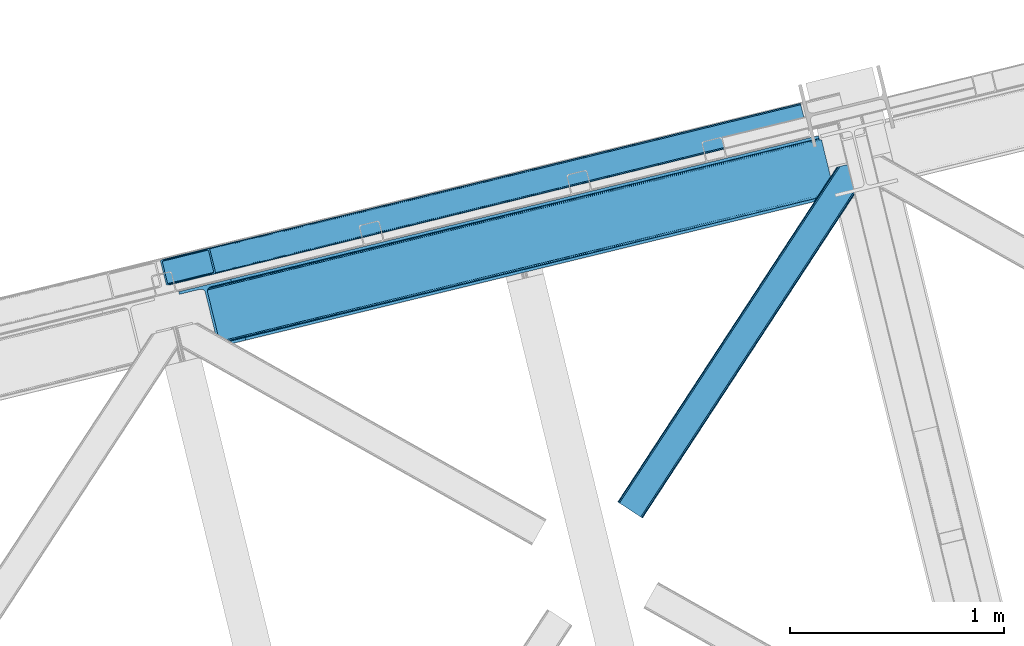
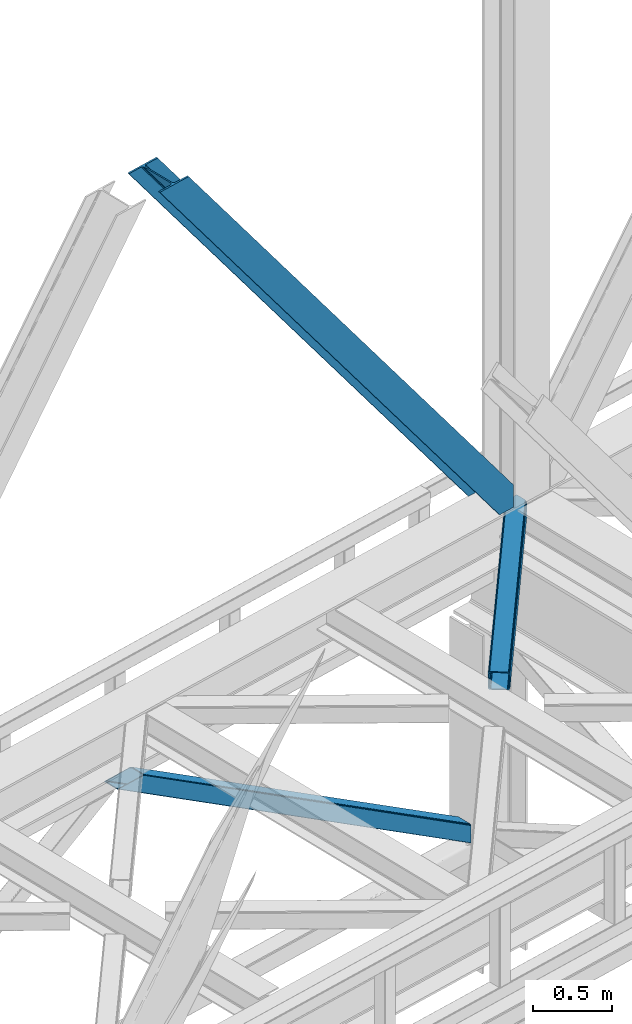
# One storey, part 49 of 93: 3 members.
"""IFC4 building model written with IfcOpenShell, lengths in millimetres."""

from ifc_helpers import new_model, entity, si_unit, converted_unit, derived_unit, direction, frame, origin, place, context, subcontext, project, spatial, triangles, type_object, element, save


model = new_model("IFC4")

# Units and contexts
model_context = context("Model", 3, precision=0.01, world=origin(), true_north=direction((6.12303176911189e-17, 1.0)))
plan_context = context("Plan", 3, precision=0.01, world=origin(), true_north=direction((6.12303176911189e-17, 1.0)))
body_context = subcontext(model_context, "Body", "Model", "MODEL_VIEW")
ifc_project = project(units=[si_unit("LENGTHUNIT", "METRE", prefix="MILLI"), si_unit("AREAUNIT", "SQUARE_METRE"), si_unit("VOLUMEUNIT", "CUBIC_METRE"), converted_unit("PLANEANGLEUNIT", "DEGREE", entity("IfcRatioMeasure", 0.0174532925199433), si_unit("PLANEANGLEUNIT", "RADIAN"), dimensions=[0, 0, 0, 0, 0, 0, 0]), si_unit("MASSUNIT", "GRAM", prefix="KILO"), derived_unit("MASSDENSITYUNIT", [(si_unit("MASSUNIT", "GRAM", prefix="KILO"), 1), (si_unit("LENGTHUNIT", "METRE"), -3)]), derived_unit("MOMENTOFINERTIAUNIT", [(si_unit("LENGTHUNIT", "METRE"), 4)]), si_unit("TIMEUNIT", "SECOND"), si_unit("FREQUENCYUNIT", "HERTZ"), si_unit("THERMODYNAMICTEMPERATUREUNIT", "DEGREE_CELSIUS"), derived_unit("THERMALTRANSMITTANCEUNIT", [(si_unit("MASSUNIT", "GRAM", prefix="KILO"), 1), (si_unit("THERMODYNAMICTEMPERATUREUNIT", "KELVIN"), -1), (si_unit("TIMEUNIT", "SECOND"), -3)]), derived_unit("VOLUMETRICFLOWRATEUNIT", [(si_unit("LENGTHUNIT", "METRE"), 3), (si_unit("TIMEUNIT", "SECOND"), -1)]), derived_unit("MASSFLOWRATEUNIT", [(si_unit("MASSUNIT", "GRAM", prefix="KILO"), 1), (si_unit("TIMEUNIT", "SECOND"), -1)]), derived_unit("ROTATIONALFREQUENCYUNIT", [(si_unit("TIMEUNIT", "SECOND"), -1)]), si_unit("ELECTRICCURRENTUNIT", "AMPERE"), si_unit("ELECTRICVOLTAGEUNIT", "VOLT"), si_unit("POWERUNIT", "WATT"), si_unit("FORCEUNIT", "NEWTON", prefix="KILO"), si_unit("ILLUMINANCEUNIT", "LUX"), si_unit("LUMINOUSFLUXUNIT", "LUMEN"), si_unit("LUMINOUSINTENSITYUNIT", "CANDELA"), derived_unit("USERDEFINED", [(si_unit("MASSUNIT", "GRAM", prefix="KILO"), -1), (si_unit("LENGTHUNIT", "METRE"), -2), (si_unit("TIMEUNIT", "SECOND"), 3), (si_unit("LUMINOUSFLUXUNIT", "LUMEN"), 1)]), derived_unit("LINEARVELOCITYUNIT", [(si_unit("LENGTHUNIT", "METRE"), 1), (si_unit("TIMEUNIT", "SECOND"), -1)]), si_unit("PRESSUREUNIT", "PASCAL"), derived_unit("USERDEFINED", [(si_unit("LENGTHUNIT", "METRE"), -2), (si_unit("MASSUNIT", "GRAM", prefix="KILO"), 1), (si_unit("TIMEUNIT", "SECOND"), -2)]), derived_unit("LINEARFORCEUNIT", [(si_unit("MASSUNIT", "GRAM", prefix="KILO"), 1), (si_unit("LENGTHUNIT", "METRE"), 1), (si_unit("TIMEUNIT", "SECOND"), -2), (si_unit("LENGTHUNIT", "METRE"), -1)]), derived_unit("PLANARFORCEUNIT", [(si_unit("MASSUNIT", "GRAM", prefix="KILO"), 1), (si_unit("LENGTHUNIT", "METRE"), 1), (si_unit("TIMEUNIT", "SECOND"), -2), (si_unit("LENGTHUNIT", "METRE"), -2)])], contexts=[model_context, plan_context])

# Site, building, storey
site_placement = place(None, origin())
site = spatial("IfcSite", under=ifc_project, at=site_placement, CompositionType="ELEMENT")
building_placement = place(site_placement, origin())
building = spatial("IfcBuilding", under=site, at=building_placement, CompositionType="ELEMENT")
storey_placement = place(building_placement, frame((0.0, 0.0, 15900.0)))
storey = spatial("IfcBuildingStorey", under=building, at=storey_placement, CompositionType="ELEMENT", Elevation=15900.0)

# Members
member_type_1 = type_object("IfcMemberType", PredefinedType="BRACE")
member_1_placement = place(storey_placement, frame((-39710.0459106445, 10977.8159729004, 3694.99929199219)))
element("IfcMember", 1, at=member_1_placement, inside=storey, type_object=member_type_1, ObjectType="Steel Vertical Brace", PredefinedType="BRACE", context=body_context, shape_type="Tessellation", body=[
    triangles([(3067.37323608399, 755.491094970703, 0.827856445310317), (3068.03133544922, 754.507434082032, 1.13248901367115), (3066.60119018555, 754.045834350585, 0.0), (3064.68037719727, 761.925585937501, 0.0), (3064.21994018555, 752.730798339844, 7.29955444335792), (3064.21994018555, 752.730798339844, 0.0), (3060.00159301758, 741.228012084961, 0.0), (3059.68998413086, 743.591821289063, 30.563250732419), (3059.80625610352, 742.210510253906, 42.2602111816377), (3059.82020874024, 745.527749633789, 0.0), (3059.82020874024, 745.527749633789, 24.1799194335908), (3059.80625610352, 742.210510253906, 171.115136718749), (3060.00159301758, 741.228012084961, 171.175598144531), (3061.30151367188, 749.56936340332, 14.6921264648408), (3061.30151367188, 749.56936340332, 0.0), (3060.72247924805, 747.995040893555, 18.3872497558586), (215.726367187504, 48.9353851318356, 3911.00081176758), (310.455468749999, 72.0269989013668, 3911.00081176758), (192.839392089845, 54.7931671142578, 3911.00081176758), (198.973901367186, 50.2783264160153, 3911.00081176758), (207.010620117188, 48.2214752197269, 3911.00081176758), (189.537268066408, 61.0788299560554, 3911.00081176758), (3062.8432800293, 729.569421386719, 171.175598144531), (313.534350585942, 59.396374511718, 3911.00081176758), (3062.8432800293, 729.569421386719, 0.0), (2945.01326293946, 700.846755981445, 0.0), (69.865502929686, 0.0, 3911.00081176758), (2941.93438110351, 713.477380371094, 0.0), (66.78662109375, 12.6294616699215, 3911.00081176758), (161.511071777342, 35.7199127197273, 3911.00081176758), (3036.65883178711, 736.567831420898, 0.0), (3054.32752075195, 759.401321411133, 0.0), (3054.28798828125, 752.301754760741, 0.0), (179.17976074219, 58.5534027099602, 3911.00081176758), (179.142553710939, 51.4549987792961, 3911.00081176758), (3050.91842651367, 745.469613647461, 0.0), (175.770666503908, 44.622857666016, 3911.00081176758), (3044.72810668946, 739.944369506837, 0.0), (169.580346679686, 39.0976135253914, 3911.00081176758), (2999.1448425293, 985.772387695313, 0.0), (124.001733398436, 284.925631713868, 3911.00081176758), (2972.9510925293, 997.914669799804, 0.0), (2981.66916503906, 998.62974243164, 0.0), (106.523730468754, 297.781823730469, 3911.00081176758), (97.8079833984375, 297.067913818359, 3911.00081176758), (2989.70820922852, 996.572891235352, 0.0), (114.560449218749, 295.726135253906, 3911.00081176758), (2995.84504394532, 992.058050537109, 0.0), (120.699609374999, 291.211294555664, 3911.00081176758), (3.07888183593604, 273.977462768555, 3911.00081176758), (2878.22664184571, 974.82421875, 0.0), (2875.14776000976, 987.454843139649, 0.0), (0.0, 286.608087158203, 3911.00081176758), (3009.50002441406, 988.296652221679, 0.0), (134.354589843751, 287.449896240234, 3911.00081176758), (143.954003906249, 306.906848144532, 3911.00081176758), (243.668847656249, 346.004461669922, 3911.00081176758), (152.023278808592, 310.283386230469, 3911.00081176758), (137.763684082034, 301.381604003906, 3911.00081176758), (134.396447753905, 294.549462890625, 3911.00081176758), (246.747729492192, 333.373837280273, 3911.00081176758), (2992.98010253906, 1016.17750854492, 171.175598144531), (2992.98010253906, 1016.17750854492, 0.0), (2995.82178955078, 1004.51891784668, 171.175598144531), (2996.10084228516, 1003.55734863281, 171.115136718749), (2996.10084228516, 1003.55734863281, 42.2602111816377), (2995.82178955078, 1004.51891784668, 0.0), (3004.86077270508, 996.247329711914, 0.0), (2997.63795776368, 1000.61683044434, 0.0), (3000.81450805664, 997.712356567383, 0.0), (3007.57921142579, 996.175241088868, 0.0), (2996.63336791992, 1002.27719421387, 30.563250732419), (2997.80306396484, 1000.74124145508, 25.1542785644524), (2999.21228027344, 998.890191650391, 18.6337463378877), (3000.81450805664, 997.712356567383, 14.6921264648408), (3004.86077270508, 996.247329711914, 7.29955444335792), (3009.06051635742, 996.424063110351, 1.13248901367115), (3008.93029174805, 995.248553466798, 0.827856445310317)], [[1, 2, 3], [3, 4, 1], [5, 6, 3], [7, 8, 9], [7, 10, 11], [11, 8, 7], [9, 12, 13], [13, 7, 9], [14, 10, 15], [10, 14, 16], [11, 10, 16], [6, 5, 15], [14, 15, 5], [3, 2, 5], [17, 18, 12], [12, 9, 17], [1, 19, 5], [19, 20, 16], [16, 14, 19], [14, 5, 19], [20, 21, 8], [8, 11, 20], [9, 8, 21], [21, 17, 9], [11, 16, 20], [5, 2, 1], [1, 4, 19], [22, 19, 4], [13, 12, 18], [23, 13, 24], [18, 24, 13], [23, 25, 7], [7, 13, 23], [24, 26, 23], [24, 27, 26], [26, 25, 23], [28, 26, 29], [27, 29, 26], [29, 30, 28], [31, 28, 30], [32, 33, 34], [35, 34, 33], [33, 36, 35], [37, 35, 36], [36, 38, 37], [39, 37, 38], [38, 31, 39], [30, 39, 31], [40, 32, 34], [34, 41, 40], [42, 43, 44], [44, 45, 42], [43, 46, 47], [47, 44, 43], [46, 48, 49], [49, 47, 46], [48, 40, 41], [41, 49, 48], [45, 50, 51], [51, 42, 45], [52, 51, 50], [50, 53, 52], [4, 54, 55], [55, 22, 4], [41, 34, 55], [37, 39, 21], [30, 27, 24], [29, 27, 30], [39, 30, 17], [34, 35, 19], [35, 37, 20], [47, 56, 44], [53, 45, 57], [45, 44, 58], [53, 50, 45], [47, 49, 59], [49, 41, 60], [55, 34, 22], [17, 21, 39], [19, 35, 20], [21, 20, 37], [19, 22, 34], [24, 17, 30], [24, 18, 17], [58, 44, 56], [59, 49, 60], [55, 60, 41], [59, 56, 47], [58, 57, 45], [57, 58, 61], [57, 52, 53], [52, 57, 62], [63, 52, 62], [64, 62, 57], [65, 64, 61], [57, 61, 64], [61, 58, 65], [66, 65, 58], [64, 67, 62], [63, 62, 67], [32, 40, 54], [46, 43, 67], [42, 52, 63], [51, 52, 42], [43, 42, 63], [40, 48, 68], [48, 46, 69], [36, 7, 38], [26, 31, 25], [31, 38, 25], [26, 28, 31], [36, 33, 10], [33, 32, 6], [10, 7, 36], [54, 40, 68], [67, 69, 46], [63, 67, 43], [48, 69, 70], [70, 68, 48], [71, 54, 68], [32, 54, 4], [10, 33, 15], [33, 6, 15], [7, 25, 38], [32, 4, 6], [3, 6, 4], [67, 72, 73], [65, 66, 64], [67, 64, 66], [66, 72, 67], [69, 74, 75], [69, 73, 74], [76, 77, 71], [71, 68, 76], [76, 68, 70], [70, 75, 76], [75, 70, 69], [73, 69, 67], [60, 78, 76], [76, 59, 60], [76, 75, 59], [75, 74, 59], [78, 77, 76], [54, 78, 60], [60, 55, 54], [73, 59, 74], [59, 73, 72], [56, 59, 72], [72, 66, 56], [58, 56, 66], [77, 78, 71], [54, 71, 78]]),
])
member_type_2 = type_object("IfcMemberType", PredefinedType="BRACE")
member_2_placement = place(storey_placement, frame((-39794.7663208008, 11294.56640625, 965.733325195311)))
element("IfcMember", 2, at=member_2_placement, inside=storey, type_object=member_type_2, ObjectType="Steel Vertical Brace", PredefinedType="BRACE", context=body_context, shape_type="Tessellation", body=[
    triangles([(2980.25064697265, 840.910299682617, 4.31950378417969), (3005.96535644531, 734.986532592773, 4.46135559082177), (0.0, 110.814166259766, 1902.27458496094), (25.9333007812456, 4.94504699707068, 1902.27458496094), (2993.26380615234, 851.573602294922, 0.777859497069585), (7.35769042968604, 120.227545166015, 1902.27458496094), (12.8643310546831, 122.203005981446, 1902.27458496094), (2986.92233276367, 848.369146728515, 1.96848449706886), (2993.30101318359, 851.416635131836, 0.0), (2.98121337890188, 117.368417358399, 1902.27458496094), (2993.0870727539, 852.292163085938, 4.33810729980542), (2981.60870361328, 844.396133422852, 3.70675048827979), (0.39532470703125, 114.063967895509, 1902.27458496094), (3022.51783447265, 731.559997558594, 0.863900756834482), (3022.69224243164, 730.848413085938, 4.42647399902489), (42.611352539061, 0.792974853515261, 1902.27458496094), (36.8117065429688, 0.0, 1902.27458496094), (31.6073730468706, 0.510433959962029, 1902.27458496094), (3015.30432128906, 731.450701904298, 2.12545166015479), (3008.76751098633, 732.521566772461, 3.85557861328198), (27.7890014648438, 2.24753723144568, 1902.27458496094), (3022.48295288086, 731.707662963867, 0.126736450194585), (2993.0870727539, 852.292163085938, 132.50470275879), (214.121813964841, 171.505810546876, 1902.27458496094), (219.916809082031, 172.298785400391, 1902.27458496094), (2993.36612548828, 851.153860473632, 135.831243896486), (225.121142578122, 171.788351440429, 1902.27458496094), (2993.6428527832, 850.015557861328, 139.157785034178), (228.939514160156, 170.052410888673, 1902.27458496094), (2994.3125793457, 847.268051147461, 140.537933349609), (230.795214843747, 167.353738403321, 1902.27458496094), (2994.9823059082, 844.520544433593, 141.916918945313), (3020.79700927734, 738.621194458008, 141.994821166991), (256.728515625, 61.484619140625, 1902.27458496094), (3021.46673583984, 735.872525024415, 140.619323730469), (3022.13646240234, 733.125018310548, 139.243826293947), (256.333190917969, 58.2359802246101, 1902.27458496094), (3022.41318969726, 731.986715698242, 135.918447875978), (253.747302246091, 54.9303680419926, 1902.27458496094), (3022.69224243164, 730.848413085938, 132.593069458009), (249.370825195307, 52.0724029541016, 1902.27458496094), (243.86418457031, 50.0957794189453, 1902.27458496094), (2994.85905761718, 840.37196044922, 0.32439880371021), (3018.6855102539, 742.222137451172, 0.455786132813955), (3020.39703369141, 740.260629272461, 0.11743469238354), (2995.40553588867, 842.785766601563, 0.00930175781104481), (8.33437499999854, 108.738711547852, 1902.27458496094), (32.3701171875, 10.6388854980469, 1902.27458496094), (2994.71488037109, 845.623965454102, 3.0765563964851), (2994.18002929687, 847.814529418945, 5.44501647949073), (15.6967163085938, 118.150927734376, 1902.27458496094), (2995.25903320313, 843.390380859375, 0.662750244140625), (11.3155883789004, 115.292962646485, 1902.27458496094), (8.73435058593168, 111.987350463867, 1902.27458496094), (2994.03585205078, 848.406353759767, 9.04363403320167), (21.2033569335908, 120.127551269532, 1902.27458496094), (34.2211669921817, 7.94137573242188, 1902.27458496094), (3020.55516357422, 739.609506225586, 0.589498901368643), (38.0395385742158, 6.20427246093823, 1902.27458496094), (3021.19000854492, 737.010827636719, 2.47426757812354), (43.2438720703067, 5.6938385009762, 1902.27458496094), (3021.46673583984, 735.872525024415, 5.80080871581958), (49.0435180664063, 6.48797607421875, 1902.27458496094), (3021.74346313476, 734.734222412109, 9.12734985351563), (2994.03585205078, 848.406353759767, 127.803826904295), (207.684997558594, 165.811972045898, 1902.27458496094), (2995.26135864257, 843.382241821289, 135.837057495119), (2995.93108520508, 840.633572387696, 137.216043090819), (224.3583984375, 161.659899902344, 1902.27458496094), (2994.58930664062, 846.129748535157, 134.456909179688), (222.507348632811, 164.357409667969, 1902.27458496094), (2994.3125793457, 847.268051147461, 131.130368041991), (218.688977050777, 166.094512939453, 1902.27458496094), (213.484643554686, 166.604946899415, 1902.27458496094), (247.998815917963, 60.3114349365242, 1902.27458496094), (248.394140624994, 63.5600738525391, 1902.27458496094), (235.525158691402, 52.1712341308594, 1902.27458496094), (245.412927246092, 57.0069854736339, 1902.27458496094), (241.031799316406, 54.1478576660156, 1902.27458496094), (3021.46673583984, 735.872525024415, 131.211758422851), (3021.74346313476, 734.734222412109, 127.887542724609), (3021.19000854492, 737.010827636719, 134.53713684082), (3020.52028198242, 739.759497070312, 135.912634277345), (3019.85055541992, 742.50700378418, 137.288131713867)], [[1, 2, 3], [4, 3, 2], [5, 6, 7], [6, 5, 8], [5, 9, 8], [8, 10, 6], [7, 11, 5], [8, 12, 10], [13, 10, 12], [12, 1, 13], [3, 13, 1], [14, 15, 16], [17, 18, 19], [19, 14, 17], [2, 20, 21], [21, 4, 2], [20, 19, 18], [18, 21, 20], [19, 22, 14], [16, 17, 14], [23, 11, 24], [7, 24, 11], [23, 24, 25], [26, 25, 27], [28, 27, 29], [30, 29, 31], [31, 32, 30], [29, 30, 28], [27, 28, 26], [25, 26, 23], [33, 32, 31], [31, 34, 33], [35, 33, 34], [36, 35, 37], [38, 36, 39], [40, 38, 41], [41, 42, 40], [39, 41, 38], [37, 39, 36], [34, 37, 35], [15, 40, 42], [42, 16, 15], [43, 44, 1], [45, 19, 44], [45, 22, 19], [46, 8, 9], [8, 46, 43], [43, 12, 8], [2, 44, 20], [20, 44, 19], [44, 2, 1], [43, 1, 12], [44, 43, 47], [47, 48, 44], [49, 50, 51], [52, 49, 53], [54, 47, 43], [43, 46, 54], [46, 52, 54], [53, 54, 52], [51, 53, 49], [50, 55, 56], [56, 51, 50], [57, 45, 44], [57, 58, 45], [45, 57, 59], [60, 59, 61], [62, 61, 63], [63, 64, 62], [61, 62, 60], [59, 60, 45], [44, 48, 57], [55, 65, 66], [66, 56, 55], [67, 68, 69], [70, 67, 71], [72, 70, 73], [65, 72, 74], [74, 66, 65], [73, 74, 72], [71, 73, 70], [69, 71, 67], [71, 27, 25], [69, 34, 31], [29, 71, 31], [71, 29, 27], [71, 69, 31], [73, 71, 25], [66, 24, 7], [24, 73, 25], [74, 24, 66], [74, 73, 24], [39, 75, 41], [76, 34, 69], [34, 75, 37], [75, 34, 76], [39, 37, 75], [42, 77, 16], [41, 75, 78], [78, 79, 42], [79, 77, 42], [42, 41, 78], [53, 6, 54], [7, 56, 66], [7, 51, 56], [53, 7, 6], [53, 51, 7], [47, 3, 4], [54, 6, 10], [13, 54, 10], [54, 13, 3], [47, 54, 3], [17, 59, 57], [16, 77, 63], [63, 61, 16], [61, 59, 16], [17, 16, 59], [18, 17, 57], [4, 48, 47], [57, 4, 21], [4, 57, 48], [21, 18, 57], [80, 40, 81], [15, 62, 64], [81, 40, 15], [22, 60, 15], [64, 81, 15], [62, 15, 60], [45, 60, 22], [80, 38, 40], [82, 35, 36], [38, 80, 82], [36, 38, 82], [83, 33, 35], [35, 82, 83], [33, 84, 32], [84, 33, 83], [65, 23, 72], [49, 9, 50], [52, 9, 49], [55, 23, 65], [11, 55, 50], [50, 9, 11], [55, 11, 23], [72, 26, 70], [67, 30, 32], [70, 30, 67], [68, 32, 84], [32, 68, 67], [70, 28, 30], [26, 72, 23], [26, 28, 70], [68, 84, 69], [76, 69, 84], [81, 77, 79], [80, 79, 78], [82, 78, 75], [83, 75, 76], [76, 84, 83], [75, 83, 82], [78, 82, 80], [79, 80, 81], [81, 64, 77], [63, 77, 64]]),
])
member_type_3 = type_object("IfcMemberType", PredefinedType="BRACE")
member_3_placement = place(storey_placement, frame((-37656.9014648438, 10204.5515441895, 3511.0000579834)))
element("IfcMember", 3, at=member_3_placement, inside=storey, type_object=member_type_3, ObjectType="Steel Horizontal Brace", PredefinedType="BRACE", context=body_context, shape_type="Tessellation", body=[
    triangles([(994.774163818358, 1564.02662658691, 0.0), (1028.82324829102, 1424.34678039551, 0.0), (14.643292236331, 67.1040435791019, 0.0), (102.486767578128, 9.58662414550781, 0.0), (1.1162109375, 75.9604797363281, 10.8028289794929), (0.0, 76.6895050048824, 17.5000946044929), (1025.02813110351, 1642.17883300781, 17.5000946044929), (4.29043579101563, 73.8826995849613, 5.12526855468968), (990.476751708986, 1585.87645568848, 9.50058288574292), (990.046545410158, 1584.44747314453, 8.74132690429906), (989.90701904297, 1583.99168701172, 8.50064392089917), (990.762780761717, 1580.48841247559, 5.12526855468968), (1027.31171264649, 1642.73461303711, 10.8702667236357), (1027.78377685547, 1642.84972229004, 9.50058288574292), (992.602203369141, 1572.93538513184, 1.33247680664135), (9.04130859374709, 70.7724243164066, 1.33247680664135), (1025.02813110351, 1642.17883300781, 122.500662231447), (0.0, 76.6895050048824, 122.500662231447), (1026.92336425781, 1642.64043273926, 129.197927856447), (1.1162109375, 75.9604797363281, 129.197927856447), (1032.31838378906, 1643.95546875, 134.874325561526), (4.29043579101563, 73.8826995849613, 134.874325561526), (1040.39463500977, 1645.92395324707, 138.667117309571), (9.04130859374709, 70.7724243164066, 138.667117309571), (1049.91963500976, 1648.24590454102, 139.999594116212), (14.643292236331, 67.1040435791019, 139.999594116212), (994.871832275392, 1567.85081176758, 9.50058288574292), (994.762536621092, 1567.00667724609, 9.29478149414354), (994.650915527345, 1566.15091552734, 9.08781738281323), (994.541619873045, 1565.30561828613, 8.8831787109375), (994.746258544925, 1564.1440612793, 8.50064392089917), (1047.05469360352, 1647.54827270508, 9.50058288574292), (14.8967651367202, 66.9377746582031, 8.3320495605476), (20.4987487792969, 63.2693939208984, 6.99957275390625), (997.043792724609, 1554.71440429688, 6.99957275390625), (10.1458923339815, 70.0480499267578, 12.1260040283232), (1042.27591552735, 1646.38322753906, 12.1260040283232), (1036.87857055664, 1645.06702880859, 17.8035644531265), (1034.9856628418, 1644.60542907715, 24.4996673583992), (6.97166748046584, 72.1258300781246, 17.8035644531265), (5.85778198242042, 72.8548553466808, 24.4996673583992), (1026.55361938477, 1433.65900268555, 6.99957275390625), (96.6313110351548, 13.420111083984, 6.99957275390625), (1028.71860351563, 1424.77582397461, 8.41343994140698), (1032.83695678711, 1407.88615722656, 5.12526855468968), (1033.6903930664, 1404.3817199707, 8.50064392089917), (1030.99520874023, 1415.43918457031, 1.33247680664135), (1034.9856628418, 1644.60542907715, 115.501089477541), (5.85778198242042, 72.8548553466808, 115.501089477541), (1050.34984130859, 1648.35171203613, 131.667544555665), (1059.87716674805, 1650.67366333008, 133.000021362306), (20.4987487792969, 63.2693939208984, 133.000021362306), (14.8967651367202, 66.9377746582031, 131.667544555665), (1042.27591552735, 1646.38322753906, 127.87475280762), (10.1458923339815, 70.0480499267578, 127.87475280762), (1036.87857055664, 1645.06702880859, 122.196029663086), (6.97166748046584, 72.1258300781246, 122.196029663086), (1128.10788574219, 1667.30520629883, 139.999594116212), (1128.10788574219, 1667.30520629883, 133.000021362306), (1144.33015136719, 1600.75810546875, 139.999594116212), (102.486767578128, 9.58662414550781, 139.999594116212), (1142.06052246094, 1610.06916503906, 133.000021362306), (96.6313110351548, 13.420111083984, 133.000021362306), (1146.50211181641, 1591.84934692383, 138.667117309571), (108.088751220705, 5.91708068847765, 138.667117309571), (1148.34385986328, 1584.29631958008, 134.874325561526), (112.839624023436, 2.80796813964844, 134.874325561526), (1149.57401733399, 1579.2501159668, 129.197927856447), (116.013848876952, 0.729025268554324, 129.197927856447), (1150.00422363282, 1577.47813110352, 122.500662231447), (117.127734374997, 0.0, 122.500662231447), (1150.00422363282, 1577.47813110352, 17.5000946044929), (117.127734374997, 0.0, 17.5000946044929), (106.98416748047, 6.64261779785193, 127.87475280762), (110.156066894531, 4.56367492675781, 122.196029663086), (111.269952392577, 3.83464965820349, 115.501089477541), (102.233294677731, 9.75173034667932, 131.667544555665), (116.013848876952, 0.729025268554324, 10.8028289794929), (106.98416748047, 6.64261779785193, 12.1260040283232), (112.839624023436, 2.80796813964844, 5.12526855468968), (111.269952392577, 3.83464965820349, 24.4996673583992), (110.156066894531, 4.56367492675781, 17.8035644531265), (108.088751220705, 5.91708068847765, 1.33247680664135), (102.233294677731, 9.75173034667932, 8.3320495605476), (1147.30438842774, 1588.56233825684, 122.196029663086), (1147.73459472656, 1586.78919067383, 115.501089477541), (1146.07423095703, 1593.60854187012, 127.87475280762), (1144.23248291016, 1601.16040649414, 131.667544555665), (1147.73459472656, 1586.78919067383, 24.4996673583992), (1147.21602172851, 1588.9239440918, 17.869839477542), (1149.994921875, 1577.51650085449, 16.5001556396492), (1147.10672607422, 1589.36461486816, 16.5001556396492), (1145.27893066406, 1573.10863037109, 10.8714294433594), (1034.62056884765, 1404.78750915527, 9.50058288574292), (1144.12783813477, 1572.03427734375, 9.50058288574292), (1142.79303588867, 1588.59721984863, 12.1260040283232), (1030.22548828125, 1422.8143157959, 9.50058288574292), (1029.19764404297, 1423.6724029541, 8.80643920898729), (1139.73275756836, 1590.05992126465, 9.50058288574292)], [[1, 2, 3], [4, 3, 2], [5, 6, 7], [8, 9, 10], [11, 12, 8], [5, 13, 9], [9, 8, 5], [13, 14, 9], [15, 1, 16], [3, 16, 1], [12, 15, 8], [16, 8, 15], [7, 13, 5], [17, 7, 6], [6, 18, 17], [19, 17, 20], [18, 20, 17], [21, 19, 22], [20, 22, 19], [23, 21, 24], [22, 24, 21], [25, 23, 26], [24, 26, 23], [27, 28, 9], [28, 29, 10], [29, 30, 10], [30, 31, 11], [14, 32, 27], [27, 9, 14], [33, 34, 35], [36, 33, 31], [31, 30, 36], [28, 36, 29], [28, 27, 36], [36, 30, 29], [32, 37, 27], [36, 27, 37], [35, 31, 33], [38, 39, 40], [41, 40, 39], [37, 38, 36], [40, 36, 38], [42, 35, 34], [34, 43, 42], [1, 35, 42], [31, 12, 11], [1, 31, 35], [31, 15, 12], [31, 1, 15], [2, 1, 42], [44, 2, 42], [45, 44, 46], [44, 47, 2], [44, 45, 47], [39, 48, 41], [49, 41, 48], [50, 51, 52], [52, 53, 50], [54, 50, 53], [53, 55, 54], [56, 54, 55], [55, 57, 56], [48, 56, 57], [57, 49, 48], [56, 17, 19], [50, 23, 25], [58, 51, 25], [51, 58, 59], [51, 50, 25], [54, 23, 50], [54, 56, 21], [21, 23, 54], [19, 21, 56], [39, 7, 17], [37, 14, 38], [56, 48, 17], [37, 32, 14], [39, 38, 7], [48, 39, 17], [13, 7, 38], [38, 14, 13], [60, 25, 61], [25, 60, 58], [26, 61, 25], [51, 62, 63], [51, 59, 62], [63, 52, 51], [64, 60, 61], [61, 65, 64], [66, 64, 65], [65, 67, 66], [68, 66, 67], [67, 69, 68], [70, 68, 69], [69, 71, 70], [72, 70, 71], [71, 73, 72], [69, 74, 75], [76, 73, 71], [69, 75, 71], [69, 67, 74], [75, 76, 71], [74, 67, 65], [63, 61, 26], [61, 77, 65], [77, 61, 63], [77, 74, 65], [78, 79, 80], [81, 73, 76], [73, 82, 78], [82, 73, 81], [78, 82, 79], [4, 43, 3], [83, 80, 79], [79, 84, 83], [84, 43, 4], [4, 83, 84], [55, 24, 22], [26, 52, 63], [26, 53, 52], [53, 26, 24], [55, 53, 24], [49, 18, 6], [20, 57, 55], [22, 20, 55], [57, 20, 18], [49, 57, 18], [16, 36, 8], [3, 43, 34], [34, 33, 3], [33, 36, 16], [16, 3, 33], [5, 8, 36], [6, 41, 49], [40, 6, 5], [6, 40, 41], [40, 5, 36], [85, 86, 75], [76, 75, 86], [87, 85, 74], [75, 74, 85], [88, 87, 77], [74, 77, 87], [62, 88, 63], [77, 63, 88], [86, 89, 81], [81, 76, 86], [90, 91, 92], [70, 72, 89], [72, 90, 89], [89, 86, 70], [72, 91, 90], [85, 70, 86], [68, 70, 85], [66, 85, 87], [85, 66, 68], [87, 64, 66], [88, 64, 87], [88, 62, 60], [88, 60, 64], [62, 58, 60], [62, 59, 58], [73, 78, 93], [93, 72, 73], [94, 93, 78], [94, 95, 93], [80, 45, 46], [46, 78, 80], [46, 94, 78], [47, 45, 83], [80, 83, 45], [2, 47, 4], [83, 4, 47], [93, 91, 72], [82, 81, 89], [82, 92, 96], [82, 90, 92], [84, 97, 98], [79, 96, 97], [97, 84, 79], [96, 99, 97], [43, 84, 44], [44, 42, 43], [96, 79, 82], [89, 90, 82], [96, 91, 93], [96, 92, 91], [96, 95, 99], [93, 95, 96], [99, 95, 97], [94, 97, 95]]),
])

save(model, "model.ifc")
